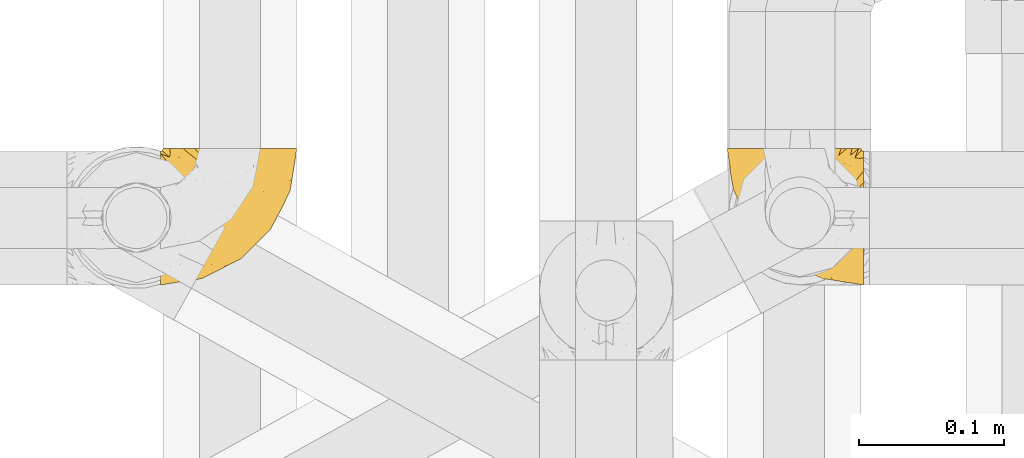
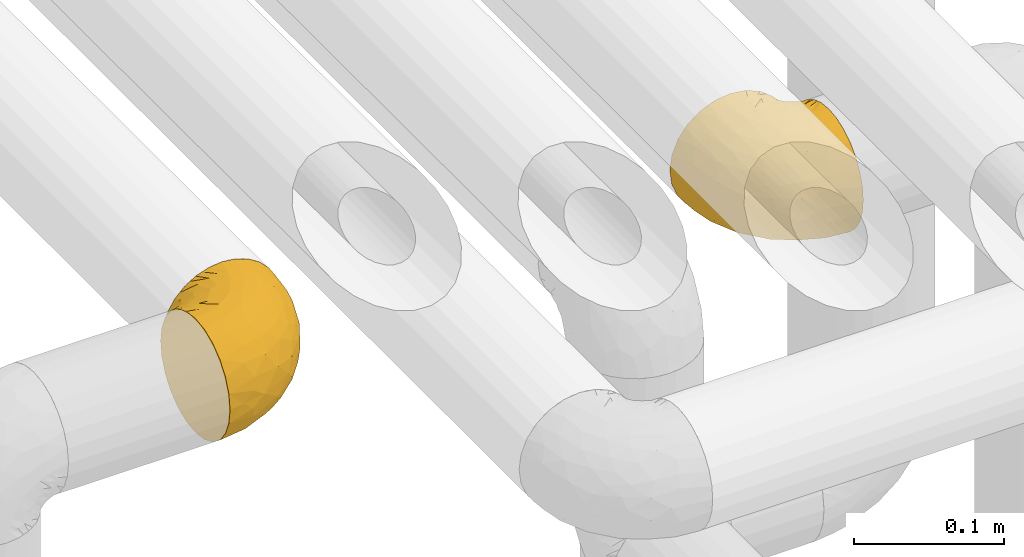
# One storey, part 175 of 827: 2 coverings.
"""IFC2X3 building model written with IfcOpenShell, lengths in millimetres."""

import ifcopenshell
import ifcopenshell.guid

model = None  # the IFC model being written
_history = None  # IfcOwnerHistory: only IFC2X3 demands one
_inside = {}  # id of a spatial element -> (the spatial element, [elements in it])
_under = {}  # id of a project, library or spatial element -> (it, [spatial elements below it])
_declared = {}  # id of a project -> (the project, [libraries it declares])
_typed = {}  # id of a type object -> (the type object, [elements of that type])
_made_of = {}  # id of a material, layer set ... -> (it, [elements and type objects made of it])


def new_model(schema):
    """Start an empty IFC model of exactly this schema.

    Asked for "IFC4X3", IfcOpenShell would pick the latest addendum, in which some entities
    have other attributes; the version numbers below select the first issue.
    IFC2X3 requires an IfcOwnerHistory on every rooted entity: one is made here for all.
    """
    global model, _history
    if schema == "IFC4X3":
        model = ifcopenshell.file(schema_version=(4, 3, 0, 0))
    else:
        model = ifcopenshell.file(schema=schema)
    _inside.clear()
    _under.clear()
    _declared.clear()
    _typed.clear()
    _made_of.clear()
    _history = None
    if model.schema == "IFC2X3":
        org = make("IfcOrganization", Name="unknown")
        user = make(
            "IfcPersonAndOrganization",
            ThePerson=make("IfcPerson", FamilyName="unknown"),
            TheOrganization=org,
        )
        app = make(
            "IfcApplication",
            ApplicationDeveloper=org,
            Version="unknown",
            ApplicationFullName="unknown",
            ApplicationIdentifier="unknown",
        )
        _history = make(
            "IfcOwnerHistory",
            OwningUser=user,
            OwningApplication=app,
            ChangeAction="ADDED",
            CreationDate=0,
        )
    return model


def make(cls, **values):
    """One entity of the class cls with the attributes given. An attribute that is None is left unset."""
    return model.create_entity(
        cls, **{name: value for name, value in values.items() if value is not None}
    )


def entity(cls, *values):
    """Any entity or typed value of the class cls, its attributes in the order of the schema. None: left unset."""
    e = model.create_entity(cls)
    for i, value in enumerate(values):
        if value is not None:
            e[i] = value
    return e


def rooted(cls, **values):
    """An entity with a GlobalId (a new one), such as an element, a storey or a relation."""
    return make(cls, GlobalId=ifcopenshell.guid.new(), OwnerHistory=_history, **values)


def si_unit(unit_type, name, prefix=None):
    """IfcSIUnit, for example si_unit("LENGTHUNIT", "METRE", prefix="MILLI")."""
    return make("IfcSIUnit", UnitType=unit_type, Prefix=prefix, Name=name)


def converted_unit(unit_type, name, factor, base, dimensions=None, offset=None):
    """IfcConversionBasedUnit, such as the inch: factor (a typed value) times the base unit."""
    return make(
        "IfcConversionBasedUnit"
        if offset is None
        else "IfcConversionBasedUnitWithOffset",
        ConversionOffset=offset,
        Dimensions=None
        if dimensions is None
        else entity("IfcDimensionalExponents", *dimensions),
        UnitType=unit_type,
        Name=name,
        ConversionFactor=make(
            "IfcMeasureWithUnit", ValueComponent=factor, UnitComponent=base
        ),
    )


def derived_unit(unit_type, elements):
    """IfcDerivedUnit: a product of units, each with its exponent."""
    return make(
        "IfcDerivedUnit",
        Elements=[
            make("IfcDerivedUnitElement", Unit=unit, Exponent=power)
            for unit, power in elements
        ],
        UnitType=unit_type,
    )


def assignment(units):
    """IfcUnitAssignment: the units of a project."""
    return None if units is None else make("IfcUnitAssignment", Units=units)


def point(xyz):
    """IfcCartesianPoint."""
    return None if xyz is None else make("IfcCartesianPoint", Coordinates=xyz)


def direction(xyz):
    """IfcDirection."""
    return None if xyz is None else make("IfcDirection", DirectionRatios=xyz)


def frame(location, z_axis=None, x_axis=None):
    """IfcAxis2Placement3D, a coordinate frame: its origin and axes. An axis left out is left unset."""
    return make(
        "IfcAxis2Placement3D",
        Location=point(location),
        Axis=direction(z_axis),
        RefDirection=direction(x_axis),
    )


def origin():
    """The frame at (0, 0, 0) with its axes left unset."""
    return frame((0.0, 0.0, 0.0))


def place(relative_to, where):
    """IfcLocalPlacement: puts the frame where relative to a parent placement (None: the world)."""
    return make(
        "IfcLocalPlacement", PlacementRelTo=relative_to, RelativePlacement=where
    )


def context(
    kind, dimensions, precision=None, world=None, true_north=None, identifier=None
):
    """IfcGeometricRepresentationContext, for example the 3D "Model" context."""
    return make(
        "IfcGeometricRepresentationContext",
        ContextIdentifier=identifier,
        ContextType=kind,
        CoordinateSpaceDimension=dimensions,
        Precision=precision,
        WorldCoordinateSystem=world,
        TrueNorth=true_north,
    )


def subcontext(parent, identifier, kind, view, scale=None):
    """IfcGeometricRepresentationSubContext, for example "Body" below "Model"."""
    return make(
        "IfcGeometricRepresentationSubContext",
        ContextIdentifier=identifier,
        ContextType=kind,
        ParentContext=parent,
        TargetScale=scale,
        TargetView=view,
    )


def project(units=None, contexts=None):
    """IfcProject with its units and contexts."""
    return rooted(
        "IfcProject",
        Name="project",
        RepresentationContexts=contexts,
        UnitsInContext=assignment(units),
    )


def spatial(cls, under=None, at=None, **own):
    """A site, building, storey or space (cls), placed at a placement, below another one or the project."""
    s = rooted(cls, ObjectPlacement=at, **own)
    if under is not None:
        _under.setdefault(under.id(), (under, []))[1].append(s)
    return s


def faces_of(points, faces, orient=None, outer=None):
    """IfcFace entities. A face is a list of loops; a loop is a list of indices into points, from 0.

    orient and outer hold one flag for each loop. By default every Orientation is true, the
    first loop of a face is its IfcFaceOuterBound and the others are IfcFaceBound.
    """
    made = []
    for i, loops in enumerate(faces):
        bounds = []
        for j, loop in enumerate(loops):
            is_outer = j == 0 if outer is None else outer[i][j]
            bounds.append(
                make(
                    "IfcFaceOuterBound" if is_outer else "IfcFaceBound",
                    Bound=make("IfcPolyLoop", Polygon=[points[k] for k in loop]),
                    Orientation=True if orient is None else orient[i][j],
                )
            )
        made.append(make("IfcFace", Bounds=bounds))
    return made


def faceted_brep(points, faces, orient=None, outer=None, voids=None):
    """IfcFacetedBrep: a solid bounded by flat faces; with voids (closed shells), ...WithVoids."""
    shared = [point(p) for p in points]
    hull = make("IfcClosedShell", CfsFaces=faces_of(shared, faces, orient, outer))
    if voids is None:
        return make("IfcFacetedBrep", Outer=hull)
    return make(
        "IfcFacetedBrepWithVoids",
        Outer=hull,
        Voids=[
            make(cls, CfsFaces=faces_of(shared, fs, o, b)) for cls, fs, o, b in voids
        ],
    )


def shape(context_of_items, identifier, shape_type, items):
    """IfcShapeRepresentation: the items that make up one representation, for example the "Body"."""
    return make(
        "IfcShapeRepresentation",
        ContextOfItems=context_of_items,
        RepresentationIdentifier=identifier,
        RepresentationType=shape_type,
        Items=items,
    )


def made_of(thing, what):
    """Note that an element or type object is made of a material, layer set ...; save() writes the relation."""
    if what is not None:
        _made_of.setdefault(what.id(), (what, []))[1].append(thing)
    return thing


def element(
    cls,
    number,
    at=None,
    inside=None,
    cuts=None,
    type_object=None,
    material=None,
    context=None,
    identifier="Body",
    shape_type=None,
    held_by="IfcProductDefinitionShape",
    body=None,
    shapes=None,
    **own,
):
    """One element of the class cls, such as IfcWall. Its Tag is "e" and its number.

    at: its placement. inside: the storey or other place that contains it. cuts: it is an
    opening in that element (IfcRelVoidsElement). A single representation is given by context,
    identifier, shape_type and body (its items); several are given by shapes. held_by: the class
    of the entity that holds the representations. save() writes the other relations.
    """
    e = rooted(cls, Tag="e%d" % number, ObjectPlacement=at, **own)
    if body is not None:
        shapes = [shape(context, identifier, shape_type, body)]
    if shapes is not None:
        e.Representation = make(held_by, Representations=shapes)
    if inside is not None:
        _inside.setdefault(inside.id(), (inside, []))[1].append(e)
    if cuts is not None:
        rooted(
            "IfcRelVoidsElement", RelatingBuildingElement=cuts, RelatedOpeningElement=e
        )
    if type_object is not None:
        _typed.setdefault(type_object.id(), (type_object, []))[1].append(e)
    return made_of(e, material)


def aggregate(whole, parts):
    """IfcRelAggregates: a whole, such as a stair, and the parts it consists of."""
    return rooted("IfcRelAggregates", RelatingObject=whole, RelatedObjects=parts)


def save(model, path):
    """Write the relations noted so far, then the file.

    IfcRelAggregates (storeys below a building ...), IfcRelContainedInSpatialStructure (elements
    in a storey), IfcRelDefinesByType, IfcRelAssociatesMaterial and IfcRelDeclares: one each for
    every whole, place, type object, material and project.
    """
    for whole, parts in _under.values():
        aggregate(whole, parts)
    for where, things in _inside.values():
        rooted(
            "IfcRelContainedInSpatialStructure",
            RelatedElements=things,
            RelatingStructure=where,
        )
    for kind, things in _typed.values():
        rooted("IfcRelDefinesByType", RelatedObjects=things, RelatingType=kind)
    for what, things in _made_of.values():
        rooted("IfcRelAssociatesMaterial", RelatedObjects=things, RelatingMaterial=what)
    for by, libraries in _declared.values():
        rooted("IfcRelDeclares", RelatingContext=by, RelatedDefinitions=libraries)
    model.write(path)


model = new_model("IFC2X3")

# Units and contexts
model_context = context("Model", 3, precision=0.01, world=origin(), true_north=direction((6.12303176911189e-17, 1.0)))
body_context = subcontext(model_context, "Body", "Model", "MODEL_VIEW")
ifc_project = project(units=[si_unit("LENGTHUNIT", "METRE", prefix="MILLI"), si_unit("AREAUNIT", "SQUARE_METRE"), si_unit("VOLUMEUNIT", "CUBIC_METRE"), converted_unit("PLANEANGLEUNIT", "DEGREE", entity("IfcRatioMeasure", 0.0174532925199433), si_unit("PLANEANGLEUNIT", "RADIAN"), dimensions=[0, 0, 0, 0, 0, 0, 0]), si_unit("MASSUNIT", "GRAM", prefix="KILO"), derived_unit("MASSDENSITYUNIT", [(si_unit("MASSUNIT", "GRAM", prefix="KILO"), 1), (si_unit("LENGTHUNIT", "METRE"), -3)]), derived_unit("MOMENTOFINERTIAUNIT", [(si_unit("LENGTHUNIT", "METRE"), 4)]), si_unit("TIMEUNIT", "SECOND"), si_unit("FREQUENCYUNIT", "HERTZ"), si_unit("THERMODYNAMICTEMPERATUREUNIT", "DEGREE_CELSIUS"), derived_unit("THERMALTRANSMITTANCEUNIT", [(si_unit("MASSUNIT", "GRAM", prefix="KILO"), 1), (si_unit("THERMODYNAMICTEMPERATUREUNIT", "KELVIN"), -1), (si_unit("TIMEUNIT", "SECOND"), -3)]), derived_unit("VOLUMETRICFLOWRATEUNIT", [(si_unit("LENGTHUNIT", "METRE"), 3), (si_unit("TIMEUNIT", "SECOND"), -1)]), derived_unit("MASSFLOWRATEUNIT", [(si_unit("MASSUNIT", "GRAM", prefix="KILO"), 1), (si_unit("TIMEUNIT", "SECOND"), -1)]), derived_unit("ROTATIONALFREQUENCYUNIT", [(si_unit("TIMEUNIT", "SECOND"), -1)]), si_unit("ELECTRICCURRENTUNIT", "AMPERE"), si_unit("ELECTRICVOLTAGEUNIT", "VOLT"), si_unit("POWERUNIT", "WATT"), si_unit("FORCEUNIT", "NEWTON", prefix="KILO"), si_unit("ILLUMINANCEUNIT", "LUX"), si_unit("LUMINOUSFLUXUNIT", "LUMEN"), si_unit("LUMINOUSINTENSITYUNIT", "CANDELA"), derived_unit("USERDEFINED", [(si_unit("MASSUNIT", "GRAM", prefix="KILO"), -1), (si_unit("LENGTHUNIT", "METRE"), -2), (si_unit("TIMEUNIT", "SECOND"), 3), (si_unit("LUMINOUSFLUXUNIT", "LUMEN"), 1)]), derived_unit("LINEARVELOCITYUNIT", [(si_unit("LENGTHUNIT", "METRE"), 1), (si_unit("TIMEUNIT", "SECOND"), -1)]), si_unit("PRESSUREUNIT", "PASCAL"), derived_unit("USERDEFINED", [(si_unit("LENGTHUNIT", "METRE"), -2), (si_unit("MASSUNIT", "GRAM", prefix="KILO"), 1), (si_unit("TIMEUNIT", "SECOND"), -2)]), derived_unit("LINEARFORCEUNIT", [(si_unit("MASSUNIT", "GRAM", prefix="KILO"), 1), (si_unit("LENGTHUNIT", "METRE"), 1), (si_unit("TIMEUNIT", "SECOND"), -2), (si_unit("LENGTHUNIT", "METRE"), -1)]), derived_unit("PLANARFORCEUNIT", [(si_unit("MASSUNIT", "GRAM", prefix="KILO"), 1), (si_unit("LENGTHUNIT", "METRE"), 1), (si_unit("TIMEUNIT", "SECOND"), -2), (si_unit("LENGTHUNIT", "METRE"), -2)])], contexts=[model_context])

# Site, building, storey
site_placement = place(None, origin())
site = spatial("IfcSite", under=ifc_project, at=site_placement, CompositionType="ELEMENT")
building_placement = place(site_placement, origin())
building = spatial("IfcBuilding", under=site, at=building_placement, CompositionType="ELEMENT")
storey_placement = place(building_placement, frame((0.0, 0.0, 28200.0)))
storey = spatial("IfcBuildingStorey", under=building, at=storey_placement, Name="08", CompositionType="ELEMENT", Elevation=28200.0)

# Coverings
covering_1_placement = place(storey_placement, frame((35682.24, 12958.41, 2952.2)))
element("IfcCovering", 1, at=covering_1_placement, inside=storey, Name=":ADSK_", ObjectType=":ADSK_", PredefinedType="INSULATION", context=body_context, shape_type="Brep", body=[
    faceted_brep([(95.8, 18.98, 83.91), (95.8, 11.67, 76.59), (95.8, 6.17, 67.83), (95.8, 2.75, 58.07), (95.8, 1.6, 47.8), (95.8, 2.75, 37.51), (95.8, 6.17, 27.74), (95.8, 11.68, 18.98), (95.8, 19.0, 11.67), (95.8, 27.76, 6.17), (95.8, 37.52, 2.75), (95.8, 47.8, 1.6), (95.8, 51.94, 2.06), (95.8, 55.01, 2.41), (95.8, 58.08, 2.75), (95.8, 62.96, 4.46), (95.8, 67.85, 6.17), (95.8, 72.23, 8.93), (95.8, 76.61, 11.68), (95.8, 80.26, 15.34), (95.8, 83.92, 19.0), (95.8, 89.42, 27.76), (95.8, 91.13, 32.64), (95.8, 92.84, 37.52), (95.8, 94.0, 47.8), (95.8, 92.84, 58.08), (95.8, 91.13, 62.96), (95.8, 89.42, 67.85), (95.8, 83.91, 76.61), (95.8, 80.25, 80.26), (95.8, 76.59, 83.92), (95.8, 72.21, 86.67), (95.8, 67.83, 89.42), (95.8, 62.95, 91.13), (95.8, 58.07, 92.84), (95.8, 55.0, 93.18), (95.8, 51.94, 93.53), (95.8, 47.8, 94.0), (95.8, 37.51, 92.84), (95.8, 27.74, 89.42), (94.0, 95.8, 47.8), (92.42, 95.8, 35.84), (87.81, 95.8, 24.7), (84.13, 95.8, 19.91), (80.46, 95.8, 15.13), (75.68, 95.8, 11.46), (70.9, 95.8, 7.78), (65.32, 95.8, 5.48), (59.75, 95.8, 3.17), (56.14, 95.8, 2.69), (54.06, 95.8, 2.42), (51.97, 95.8, 2.14), (47.8, 95.8, 1.6), (35.84, 95.8, 3.17), (24.7, 95.8, 7.78), (15.13, 95.8, 15.13), (7.78, 95.8, 24.7), (3.17, 95.8, 35.84), (1.6, 95.8, 47.8), (3.17, 95.8, 59.75), (7.78, 95.8, 70.9), (15.13, 95.8, 80.46), (24.7, 95.8, 87.81), (35.84, 95.8, 92.42), (47.8, 95.8, 94.0), (51.97, 95.8, 93.45), (56.14, 95.8, 92.9), (59.75, 95.8, 92.42), (65.32, 95.8, 90.11), (70.9, 95.8, 87.81), (75.68, 95.8, 84.13), (80.46, 95.8, 80.46), (84.13, 95.8, 75.68), (87.81, 95.8, 70.9), (92.42, 95.8, 59.75), (15.84, 60.58, 71.98), (6.99, 74.11, 63.6), (14.39, 51.59, 59.72), (6.21, 66.69, 47.8), (4.26, 76.19, 55.16), (3.39, 84.43, 47.8), (31.2, 31.2, 63.76), (26.47, 42.88, 72.22), (11.44, 79.41, 74.18), (47.66, 60.7, 92.52), (61.85, 61.85, 94.0), (59.25, 65.75, 94.0), (56.65, 69.64, 94.0), (54.05, 73.53, 94.0), (51.45, 77.43, 94.0), (19.8, 74.59, 82.14), (26.22, 54.72, 80.34), (31.58, 64.18, 87.52), (38.36, 37.94, 79.59), (51.54, 25.89, 78.25), (51.6, 34.73, 85.01), (55.97, 42.89, 90.25), (62.88, 49.83, 93.2), (41.35, 48.58, 87.23), (82.24, 22.41, 85.55), (40.88, 78.69, 93.0), (29.0, 81.64, 89.31), (74.06, 6.22, 61.31), (54.53, 12.11, 56.86), (57.98, 14.81, 68.34), (43.81, 21.61, 65.71), (38.22, 22.41, 56.99), (38.33, 30.12, 72.15), (74.76, 10.01, 70.34), (76.85, 15.36, 78.36), (84.43, 3.39, 47.8), (40.43, 19.59, 47.8), (30.01, 30.01, 47.8), (78.67, 41.19, 93.06), (92.06, 48.54, 94.0), (88.32, 49.28, 94.0), (85.6, 49.82, 94.0), (82.88, 50.37, 94.0), (80.15, 50.91, 94.0), (77.43, 51.45, 94.0), (76.36, 31.61, 89.88), (50.91, 80.15, 94.0), (50.37, 82.88, 94.0), (49.82, 85.6, 94.0), (49.28, 88.32, 94.0), (48.91, 90.19, 94.0), (48.54, 92.06, 94.0), (66.69, 6.21, 47.8), (73.53, 54.05, 94.0), (69.64, 56.65, 94.0), (65.75, 59.25, 94.0), (66.13, 24.66, 83.7), (19.59, 40.43, 47.8), (24.64, 35.17, 55.9), (53.56, 12.9, 47.8), (12.9, 53.56, 47.8), (82.81, 85.34, 81.75), (81.22, 78.44, 86.43), (86.57, 84.37, 79.8), (92.75, 89.05, 69.84), (89.68, 82.76, 79.5), (72.26, 86.31, 88.08), (64.73, 83.73, 91.6), (62.45, 77.31, 92.93), (60.63, 87.78, 92.43), (56.91, 87.91, 93.24), (58.14, 81.29, 93.36), (93.7, 93.97, 57.25), (83.4, 70.76, 89.41), (75.54, 63.67, 92.89), (79.46, 62.62, 92.66), (82.28, 90.64, 79.58), (76.25, 84.08, 86.51), (90.18, 77.45, 83.91), (84.69, 76.28, 86.29), (86.94, 91.35, 73.94), (65.12, 88.72, 90.94), (71.71, 71.28, 91.94), (75.21, 68.09, 91.98), (78.6, 91.07, 82.79), (87.27, 57.47, 93.16), (87.92, 70.34, 88.76), (86.1, 62.99, 91.89), (94.52, 94.52, 47.8), (66.23, 76.47, 92.22), (91.08, 69.96, 88.56), (71.77, 89.86, 87.72), (76.21, 78.94, 88.33), (68.59, 73.51, 92.18), (89.94, 89.62, 71.78), (76.22, 78.96, 7.27), (81.22, 78.46, 9.17), (71.7, 71.31, 3.66), (49.28, 88.32, 1.6), (48.54, 92.06, 1.6), (50.37, 82.88, 1.6), (49.82, 85.6, 1.6), (93.7, 93.97, 38.35), (89.95, 89.63, 23.84), (82.88, 50.37, 1.6), (85.6, 49.82, 1.6), (92.06, 48.54, 1.6), (88.32, 49.28, 1.6), (89.68, 82.77, 16.1), (87.92, 70.36, 6.84), (62.45, 77.31, 2.66), (66.24, 76.47, 3.37), (56.65, 69.64, 1.6), (59.25, 65.75, 1.6), (78.6, 91.06, 12.8), (60.63, 87.78, 3.16), (56.91, 87.91, 2.35), (92.76, 89.06, 25.77), (76.25, 84.09, 9.09), (82.28, 90.65, 16.02), (82.81, 85.35, 13.85), (54.05, 73.53, 1.6), (51.45, 77.43, 1.6), (58.14, 81.29, 2.23), (90.18, 77.46, 11.69), (84.7, 76.29, 9.31), (87.25, 57.47, 2.43), (75.58, 63.71, 2.71), (75.2, 68.11, 3.61), (83.39, 70.77, 6.18), (90.73, 69.52, 6.77), (79.47, 62.64, 2.93), (86.94, 91.35, 21.66), (65.75, 59.25, 1.6), (86.75, 84.6, 16.09), (86.08, 62.98, 3.7), (77.43, 51.45, 1.6), (73.53, 54.05, 1.6), (69.64, 56.65, 1.6), (64.73, 83.73, 3.99), (50.91, 80.15, 1.6), (65.12, 88.72, 4.65), (72.26, 86.3, 7.51), (61.85, 61.85, 1.6), (68.62, 73.56, 3.43), (74.03, 91.36, 9.46), (80.15, 50.91, 1.6), (49.81, 62.87, 2.4), (4.26, 76.19, 40.43), (19.95, 73.57, 13.57), (30.61, 56.07, 11.3), (25.71, 49.77, 18.65), (22.43, 44.73, 27.26), (15.85, 60.58, 23.61), (60.69, 47.64, 3.07), (40.49, 78.32, 2.69), (14.39, 51.59, 35.87), (6.99, 74.11, 31.99), (29.56, 76.04, 6.71), (11.45, 79.41, 21.41), (57.98, 14.82, 27.24), (74.06, 6.22, 34.26), (54.52, 12.12, 38.73), (43.47, 23.51, 26.97), (31.2, 31.2, 31.83), (33.27, 34.96, 23.4), (64.26, 33.86, 6.91), (74.29, 38.94, 3.4), (80.41, 30.23, 5.84), (41.67, 20.67, 35.73), (24.64, 35.17, 39.69), (73.62, 15.85, 17.6), (78.98, 22.59, 10.38), (53.69, 21.56, 20.6), (42.86, 55.94, 5.36), (79.66, 9.19, 24.84), (58.41, 25.79, 13.87), (47.11, 41.16, 9.06), (38.37, 37.95, 15.99)], [[[0, 1, 2, 3, 4, 5, 6, 7, 8, 9, 10, 11, 12, 13, 14, 15, 16, 17, 18, 19, 20, 21, 22, 23, 24, 25, 26, 27, 28, 29, 30, 31, 32, 33, 34, 35, 36, 37, 38, 39]], [[40, 41, 42, 43, 44, 45, 46, 47, 48, 49, 50, 51, 52, 53, 54, 55, 56, 57, 58, 59, 60, 61, 62, 63, 64, 65, 66, 67, 68, 69, 70, 71, 72, 73, 74]], [[75, 76, 77]], [[78, 79, 80]], [[77, 81, 82]], [[76, 75, 83]], [[84, 85, 86, 87, 88, 89]], [[90, 91, 92]], [[76, 60, 59]], [[93, 94, 95]], [[90, 62, 61]], [[83, 61, 60]], [[96, 97, 84]], [[98, 93, 95]], [[0, 39, 99]], [[100, 84, 89]], [[62, 101, 63]], [[2, 102, 3]], [[92, 84, 100]], [[103, 102, 104]], [[103, 105, 106]], [[93, 107, 94]], [[1, 108, 2]], [[92, 101, 90]], [[108, 1, 109]], [[102, 110, 3]], [[93, 82, 107]], [[102, 108, 104]], [[111, 106, 112]], [[109, 0, 99]], [[113, 37, 114, 115, 116, 117, 118, 119]], [[120, 38, 113]], [[100, 89, 121, 122, 123, 124, 125, 126, 64]], [[127, 102, 103]], [[97, 119, 128, 129, 130, 85]], [[99, 120, 131]], [[132, 133, 77]], [[59, 80, 79]], [[1, 0, 109]], [[98, 84, 92]], [[94, 109, 131]], [[120, 39, 38]], [[93, 91, 82]], [[104, 94, 105]], [[97, 113, 119]], [[95, 120, 96]], [[83, 90, 61]], [[91, 93, 98]], [[64, 63, 100]], [[100, 63, 101]], [[77, 76, 79]], [[133, 106, 81]], [[84, 97, 85]], [[113, 96, 120]], [[113, 97, 96]], [[37, 113, 38]], [[110, 102, 127]], [[110, 4, 3]], [[103, 111, 134, 127]], [[90, 75, 91]], [[82, 81, 107]], [[91, 75, 82]], [[77, 82, 75]], [[76, 83, 60]], [[90, 83, 75]], [[105, 107, 81]], [[94, 131, 95]], [[105, 94, 107]], [[109, 94, 104]], [[120, 95, 131]], [[98, 95, 96]], [[84, 98, 96]], [[98, 92, 91]], [[106, 105, 81]], [[103, 104, 105]], [[112, 106, 133]], [[103, 106, 111]], [[112, 133, 132]], [[81, 77, 133]], [[77, 78, 135, 132]], [[120, 99, 39]], [[109, 99, 131]], [[59, 58, 80]], [[59, 79, 76]], [[90, 101, 62]], [[100, 101, 92]], [[2, 108, 102]], [[109, 104, 108]], [[78, 77, 79]], [[136, 137, 138]], [[27, 139, 140]], [[141, 142, 143]], [[144, 145, 121]], [[146, 89, 88]], [[147, 139, 25]], [[148, 149, 150]], [[136, 151, 152]], [[147, 40, 74]], [[24, 147, 25]], [[153, 140, 154]], [[33, 116, 34]], [[73, 151, 155]], [[114, 37, 36, 35, 34, 116, 115]], [[146, 156, 144]], [[157, 85, 130]], [[158, 149, 148]], [[151, 159, 152]], [[117, 33, 160]], [[29, 153, 161]], [[155, 74, 73]], [[162, 128, 119]], [[66, 65, 64, 126, 125, 124, 123, 122, 67]], [[163, 147, 24]], [[27, 140, 28]], [[149, 129, 150]], [[139, 27, 26, 25]], [[68, 144, 69]], [[129, 128, 150]], [[164, 87, 86]], [[130, 129, 149]], [[122, 145, 67]], [[153, 154, 148]], [[162, 119, 160]], [[165, 30, 161]], [[150, 161, 148]], [[128, 162, 150]], [[30, 165, 31]], [[145, 144, 68]], [[89, 146, 144]], [[87, 164, 143]], [[166, 156, 142]], [[88, 87, 143]], [[162, 161, 150]], [[161, 30, 29]], [[161, 153, 148]], [[28, 140, 153]], [[29, 28, 153]], [[140, 137, 154]], [[158, 148, 154]], [[157, 130, 158]], [[154, 137, 158]], [[158, 137, 157]], [[167, 137, 136]], [[168, 85, 157]], [[152, 168, 167]], [[167, 168, 157]], [[164, 152, 141]], [[151, 73, 72]], [[159, 72, 71]], [[88, 142, 146]], [[144, 156, 69]], [[146, 142, 156]], [[70, 166, 71]], [[142, 141, 166]], [[70, 69, 156]], [[141, 159, 71]], [[167, 136, 152]], [[138, 137, 140]], [[155, 136, 169]], [[136, 155, 151]], [[74, 155, 169]], [[152, 159, 141]], [[151, 72, 159]], [[168, 152, 164]], [[137, 167, 157]], [[164, 86, 168]], [[85, 168, 86]], [[116, 33, 117]], [[130, 149, 158]], [[67, 145, 68]], [[121, 89, 144]], [[145, 122, 121]], [[40, 147, 163]], [[169, 147, 74]], [[160, 33, 32]], [[162, 160, 32]], [[160, 119, 118, 117]], [[139, 147, 169]], [[139, 169, 138]], [[162, 32, 31]], [[141, 143, 164]], [[88, 143, 142]], [[71, 166, 141]], [[156, 166, 70]], [[139, 138, 140]], [[169, 136, 138]], [[161, 162, 165]], [[162, 31, 165]], [[170, 171, 172]], [[173, 174, 52, 51, 50, 49, 48, 175, 176]], [[177, 178, 41]], [[179, 15, 180]], [[12, 11, 181, 182, 180, 14, 13]], [[183, 21, 20]], [[19, 18, 184]], [[185, 186, 187]], [[186, 188, 187]], [[43, 189, 44]], [[190, 191, 47]], [[23, 22, 21, 192]], [[193, 194, 195]], [[40, 163, 177]], [[196, 197, 198]], [[24, 23, 177]], [[199, 200, 183]], [[201, 15, 179]], [[178, 177, 192]], [[47, 46, 190]], [[202, 203, 204]], [[203, 172, 171]], [[205, 206, 184]], [[207, 41, 178]], [[16, 15, 201]], [[14, 180, 15]], [[204, 203, 200]], [[208, 203, 202]], [[163, 24, 177]], [[48, 47, 191]], [[198, 197, 190]], [[199, 184, 204]], [[171, 195, 209]], [[210, 211, 212]], [[206, 212, 213]], [[205, 17, 210]], [[184, 206, 204]], [[210, 212, 206]], [[185, 196, 214]], [[190, 215, 191]], [[216, 45, 214]], [[186, 217, 193]], [[190, 216, 198]], [[199, 20, 19]], [[196, 185, 187]], [[199, 183, 20]], [[184, 199, 19]], [[199, 204, 200]], [[206, 202, 204]], [[171, 183, 200]], [[203, 208, 172]], [[172, 208, 218]], [[171, 200, 203]], [[218, 188, 219]], [[195, 170, 193]], [[217, 186, 185]], [[193, 219, 186]], [[193, 170, 219]], [[207, 194, 42]], [[217, 220, 189]], [[216, 190, 46]], [[214, 196, 198]], [[44, 220, 45]], [[214, 198, 216]], [[216, 46, 45]], [[214, 45, 220]], [[42, 194, 43]], [[189, 193, 217]], [[207, 195, 194]], [[209, 195, 178]], [[41, 207, 42]], [[195, 207, 178]], [[43, 194, 189]], [[193, 189, 194]], [[171, 170, 195]], [[170, 172, 219]], [[218, 219, 172]], [[188, 186, 219]], [[206, 213, 202]], [[208, 202, 213]], [[201, 210, 16]], [[215, 190, 197]], [[215, 175, 191]], [[175, 48, 191]], [[201, 179, 221, 211]], [[210, 201, 211]], [[23, 192, 177]], [[40, 177, 41]], [[192, 183, 209]], [[21, 183, 192]], [[205, 18, 17]], [[17, 16, 210]], [[217, 185, 214]], [[189, 220, 44]], [[214, 220, 217]], [[192, 209, 178]], [[171, 209, 183]], [[206, 205, 210]], [[18, 205, 184]], [[222, 197, 196, 187, 188, 218]], [[57, 223, 80]], [[224, 225, 226]], [[226, 227, 228]], [[229, 218, 208, 213, 212, 211]], [[230, 52, 174, 173, 176, 175, 215, 197]], [[231, 232, 228]], [[231, 78, 223]], [[223, 57, 232]], [[224, 233, 225]], [[233, 54, 53]], [[234, 232, 56]], [[56, 55, 234]], [[234, 224, 228]], [[235, 236, 237]], [[224, 55, 54]], [[238, 239, 240]], [[52, 230, 53]], [[241, 242, 243]], [[239, 244, 245]], [[11, 10, 242]], [[236, 6, 5]], [[7, 246, 8]], [[8, 247, 9]], [[238, 248, 235]], [[222, 229, 249]], [[242, 211, 221, 179, 180, 182, 181, 11]], [[233, 53, 230]], [[111, 112, 244]], [[250, 6, 236]], [[247, 251, 241]], [[6, 250, 7]], [[127, 236, 110]], [[249, 229, 252]], [[247, 8, 246]], [[235, 246, 250]], [[236, 5, 110]], [[235, 244, 238]], [[237, 236, 127]], [[243, 9, 247]], [[252, 229, 241]], [[56, 232, 57]], [[222, 230, 197]], [[225, 249, 252]], [[249, 233, 230]], [[54, 233, 224]], [[231, 228, 227]], [[245, 132, 231]], [[249, 225, 233]], [[226, 225, 253]], [[235, 250, 236]], [[246, 7, 250]], [[251, 247, 246]], [[243, 247, 241]], [[248, 246, 235]], [[252, 251, 253]], [[229, 222, 218]], [[230, 222, 249]], [[5, 4, 110]], [[237, 127, 134, 111]], [[238, 244, 239]], [[224, 234, 55]], [[232, 234, 228]], [[242, 241, 229]], [[10, 9, 243]], [[211, 242, 229]], [[10, 243, 242]], [[80, 223, 78]], [[80, 58, 57]], [[231, 223, 232]], [[227, 240, 239]], [[224, 226, 228]], [[240, 226, 253]], [[227, 239, 245]], [[226, 240, 227]], [[251, 248, 253]], [[240, 253, 248]], [[244, 235, 237]], [[237, 111, 244]], [[132, 245, 112]], [[112, 245, 244]], [[135, 78, 231, 132]], [[227, 245, 231]], [[248, 238, 240]], [[246, 248, 251]], [[251, 252, 241]], [[225, 252, 253]]]),
])
covering_2_placement = place(storey_placement, frame((35290.44, 12958.41, 2952.2)))
element("IfcCovering", 2, at=covering_2_placement, inside=storey, Name=":ADSK_", ObjectType=":ADSK_", PredefinedType="INSULATION", context=body_context, shape_type="Brep", body=[
    faceted_brep([(78.41, 95.8, 83.91), (85.72, 95.8, 76.59), (91.22, 95.8, 67.83), (94.64, 95.8, 58.07), (95.8, 95.8, 47.8), (94.64, 95.8, 37.51), (91.22, 95.8, 27.74), (85.71, 95.8, 18.98), (78.39, 95.8, 11.67), (69.63, 95.8, 6.17), (59.87, 95.8, 2.75), (49.6, 95.8, 1.6), (45.45, 95.8, 2.06), (42.38, 95.8, 2.41), (39.31, 95.8, 2.75), (34.43, 95.8, 4.46), (29.54, 95.8, 6.17), (25.16, 95.8, 8.93), (20.78, 95.8, 11.68), (17.13, 95.8, 15.34), (13.47, 95.8, 19.0), (7.97, 95.8, 27.76), (6.26, 95.8, 32.64), (4.55, 95.8, 37.52), (3.4, 95.8, 47.8), (4.55, 95.8, 58.08), (6.26, 95.8, 62.96), (7.97, 95.8, 67.85), (13.48, 95.8, 76.61), (17.14, 95.8, 80.26), (20.8, 95.8, 83.92), (25.18, 95.8, 86.67), (29.56, 95.8, 89.42), (34.44, 95.8, 91.13), (39.32, 95.8, 92.84), (42.39, 95.8, 93.18), (45.45, 95.8, 93.53), (49.6, 95.8, 94.0), (59.88, 95.8, 92.84), (69.65, 95.8, 89.42), (1.6, 94.0, 47.8), (1.6, 92.42, 35.84), (1.6, 87.81, 24.7), (1.6, 84.13, 19.91), (1.6, 80.46, 15.13), (1.6, 75.68, 11.46), (1.6, 70.9, 7.78), (1.6, 65.32, 5.48), (1.6, 59.75, 3.17), (1.6, 56.14, 2.69), (1.6, 54.06, 2.42), (1.6, 51.97, 2.14), (1.6, 47.8, 1.6), (1.6, 35.84, 3.17), (1.6, 24.7, 7.78), (1.6, 15.13, 15.13), (1.6, 7.78, 24.7), (1.6, 3.17, 35.84), (1.6, 1.6, 47.8), (1.6, 3.17, 59.75), (1.6, 7.78, 70.9), (1.6, 15.13, 80.46), (1.6, 24.7, 87.81), (1.6, 35.84, 92.42), (1.6, 47.8, 94.0), (1.6, 51.97, 93.45), (1.6, 56.14, 92.9), (1.6, 59.75, 92.42), (1.6, 65.32, 90.11), (1.6, 70.9, 87.81), (1.6, 75.68, 84.13), (1.6, 80.46, 80.46), (1.6, 84.13, 75.68), (1.6, 87.81, 70.9), (1.6, 92.42, 59.75), (36.81, 15.84, 71.98), (23.28, 6.99, 63.6), (45.8, 14.39, 59.72), (30.7, 6.21, 47.8), (21.2, 4.26, 55.16), (12.96, 3.39, 47.8), (66.19, 31.2, 63.76), (54.51, 26.47, 72.22), (17.98, 11.44, 74.18), (36.69, 47.66, 92.52), (35.54, 61.85, 94.0), (31.64, 59.25, 94.0), (27.75, 56.65, 94.0), (23.86, 54.05, 94.0), (19.96, 51.45, 94.0), (22.8, 19.8, 82.14), (42.67, 26.22, 80.34), (33.21, 31.58, 87.52), (59.45, 38.36, 79.59), (71.5, 51.54, 78.25), (62.66, 51.6, 85.01), (54.5, 55.97, 90.25), (47.57, 62.88, 93.2), (48.81, 41.35, 87.23), (74.98, 82.24, 85.55), (18.7, 40.88, 93.0), (15.75, 29.0, 89.31), (91.17, 74.06, 61.31), (85.28, 54.53, 56.86), (82.58, 57.98, 68.34), (75.78, 43.81, 65.71), (74.98, 38.22, 56.99), (67.27, 38.33, 72.15), (87.38, 74.76, 70.34), (82.04, 76.85, 78.36), (94.0, 84.43, 47.8), (77.8, 40.43, 47.8), (67.38, 30.01, 47.8), (56.2, 78.67, 93.06), (48.85, 92.06, 94.0), (48.11, 88.32, 94.0), (47.57, 85.6, 94.0), (47.03, 82.88, 94.0), (46.48, 80.15, 94.0), (45.94, 77.43, 94.0), (65.78, 76.36, 89.88), (17.24, 50.91, 94.0), (14.51, 50.37, 94.0), (11.79, 49.82, 94.0), (9.07, 49.28, 94.0), (7.2, 48.91, 94.0), (5.33, 48.54, 94.0), (91.18, 66.69, 47.8), (43.34, 73.53, 94.0), (40.74, 69.64, 94.0), (38.14, 65.75, 94.0), (72.73, 66.13, 83.7), (56.96, 19.59, 47.8), (62.23, 24.64, 55.9), (84.49, 53.56, 47.8), (43.83, 12.9, 47.8), (12.05, 82.81, 81.75), (18.95, 81.22, 86.43), (13.02, 86.57, 79.8), (8.34, 92.75, 69.84), (14.63, 89.68, 79.5), (11.09, 72.26, 88.08), (13.66, 64.73, 91.6), (20.08, 62.45, 92.93), (9.61, 60.63, 92.43), (9.48, 56.91, 93.24), (16.1, 58.14, 93.36), (3.42, 93.7, 57.25), (26.63, 83.4, 89.41), (33.72, 75.54, 92.89), (34.77, 79.46, 92.66), (6.75, 82.28, 79.58), (13.31, 76.25, 86.51), (21.11, 84.69, 86.29), (19.94, 90.18, 83.91), (6.04, 86.94, 73.94), (8.67, 65.12, 90.94), (26.11, 71.71, 91.94), (29.3, 75.21, 91.98), (6.32, 78.6, 82.79), (39.92, 87.27, 93.16), (27.05, 87.92, 88.76), (34.4, 86.1, 91.89), (2.87, 94.52, 47.8), (20.92, 66.23, 92.22), (27.43, 91.08, 88.56), (7.54, 71.77, 87.72), (18.45, 76.21, 88.33), (23.88, 68.59, 92.18), (7.77, 89.94, 71.78), (13.3, 76.25, 9.09), (11.09, 72.26, 7.51), (6.33, 78.6, 12.8), (9.07, 49.28, 1.6), (5.33, 48.54, 1.6), (14.51, 50.37, 1.6), (11.79, 49.82, 1.6), (3.42, 93.7, 38.35), (7.76, 89.95, 23.84), (47.03, 82.88, 1.6), (47.57, 85.6, 1.6), (48.85, 92.06, 1.6), (48.11, 88.32, 1.6), (14.62, 89.68, 16.1), (27.03, 87.92, 6.84), (20.08, 62.45, 2.66), (20.92, 66.24, 3.37), (27.75, 56.65, 1.6), (31.64, 59.25, 1.6), (9.61, 60.63, 3.16), (9.48, 56.91, 2.35), (8.33, 92.76, 25.77), (6.74, 82.28, 16.02), (12.04, 82.81, 13.85), (23.86, 54.05, 1.6), (19.96, 51.45, 1.6), (16.1, 58.14, 2.23), (19.93, 90.18, 11.69), (21.1, 84.7, 9.31), (39.92, 87.25, 2.43), (33.68, 75.58, 2.71), (29.28, 75.2, 3.61), (26.62, 83.39, 6.18), (26.08, 71.7, 3.66), (18.93, 81.22, 9.17), (27.87, 90.73, 6.77), (34.75, 79.47, 2.93), (6.04, 86.94, 21.66), (38.14, 65.75, 1.6), (12.79, 86.75, 16.09), (34.41, 86.08, 3.7), (45.94, 77.43, 1.6), (43.34, 73.53, 1.6), (40.74, 69.64, 1.6), (13.66, 64.73, 3.99), (17.24, 50.91, 1.6), (8.67, 65.12, 4.65), (35.54, 61.85, 1.6), (23.83, 68.62, 3.43), (18.43, 76.22, 7.27), (6.03, 74.03, 9.46), (46.48, 80.15, 1.6), (34.52, 49.81, 2.4), (21.2, 4.26, 40.43), (23.82, 19.95, 13.57), (41.32, 30.61, 11.3), (47.62, 25.71, 18.65), (52.66, 22.43, 27.26), (36.81, 15.85, 23.61), (49.75, 60.69, 3.07), (19.07, 40.49, 2.69), (45.8, 14.39, 35.87), (23.28, 6.99, 31.99), (21.35, 29.56, 6.71), (17.98, 11.45, 21.41), (82.57, 57.98, 27.24), (91.17, 74.06, 34.26), (85.27, 54.52, 38.73), (73.89, 43.47, 26.97), (66.19, 31.2, 31.83), (62.43, 33.27, 23.4), (63.53, 64.26, 6.91), (58.45, 74.29, 3.4), (67.16, 80.41, 5.84), (62.22, 24.64, 39.69), (81.54, 73.62, 17.6), (74.8, 78.98, 10.38), (75.83, 53.69, 20.6), (41.45, 42.86, 5.36), (76.72, 41.67, 35.73), (88.2, 79.66, 24.84), (71.6, 58.41, 13.87), (56.23, 47.11, 9.06), (59.44, 38.37, 15.99)], [[[0, 1, 2, 3, 4, 5, 6, 7, 8, 9, 10, 11, 12, 13, 14, 15, 16, 17, 18, 19, 20, 21, 22, 23, 24, 25, 26, 27, 28, 29, 30, 31, 32, 33, 34, 35, 36, 37, 38, 39]], [[40, 41, 42, 43, 44, 45, 46, 47, 48, 49, 50, 51, 52, 53, 54, 55, 56, 57, 58, 59, 60, 61, 62, 63, 64, 65, 66, 67, 68, 69, 70, 71, 72, 73, 74]], [[75, 76, 77]], [[78, 79, 80]], [[77, 81, 82]], [[76, 75, 83]], [[84, 85, 86, 87, 88, 89]], [[90, 91, 92]], [[76, 60, 59]], [[93, 94, 95]], [[90, 62, 61]], [[83, 61, 60]], [[96, 97, 84]], [[98, 93, 95]], [[0, 39, 99]], [[100, 84, 89]], [[62, 101, 63]], [[2, 102, 3]], [[92, 84, 100]], [[103, 102, 104]], [[103, 105, 106]], [[93, 107, 94]], [[1, 108, 2]], [[92, 101, 90]], [[108, 1, 109]], [[102, 110, 3]], [[93, 82, 107]], [[102, 108, 104]], [[111, 106, 112]], [[109, 0, 99]], [[113, 37, 114, 115, 116, 117, 118, 119]], [[120, 38, 113]], [[100, 89, 121, 122, 123, 124, 125, 126, 64]], [[127, 102, 103]], [[97, 119, 128, 129, 130, 85]], [[99, 120, 131]], [[132, 133, 77]], [[59, 80, 79]], [[1, 0, 109]], [[98, 84, 92]], [[94, 109, 131]], [[120, 39, 38]], [[93, 91, 82]], [[104, 94, 105]], [[97, 113, 119]], [[95, 120, 96]], [[83, 90, 61]], [[91, 93, 98]], [[64, 63, 100]], [[100, 63, 101]], [[77, 76, 79]], [[133, 106, 81]], [[84, 97, 85]], [[113, 96, 120]], [[113, 97, 96]], [[37, 113, 38]], [[110, 102, 127]], [[110, 4, 3]], [[103, 111, 134, 127]], [[90, 75, 91]], [[82, 81, 107]], [[91, 75, 82]], [[77, 82, 75]], [[76, 83, 60]], [[90, 83, 75]], [[105, 107, 81]], [[94, 131, 95]], [[105, 94, 107]], [[109, 94, 104]], [[120, 95, 131]], [[98, 95, 96]], [[84, 98, 96]], [[98, 92, 91]], [[106, 105, 81]], [[103, 104, 105]], [[112, 106, 133]], [[103, 106, 111]], [[112, 133, 132]], [[81, 77, 133]], [[77, 78, 135, 132]], [[120, 99, 39]], [[109, 99, 131]], [[59, 58, 80]], [[59, 79, 76]], [[90, 101, 62]], [[100, 101, 92]], [[2, 108, 102]], [[109, 104, 108]], [[78, 77, 79]], [[136, 137, 138]], [[27, 139, 140]], [[141, 142, 143]], [[144, 145, 121]], [[146, 89, 88]], [[147, 139, 25]], [[148, 149, 150]], [[136, 151, 152]], [[147, 40, 74]], [[24, 147, 25]], [[140, 153, 154]], [[33, 116, 34]], [[73, 151, 155]], [[114, 37, 36, 35, 34, 116, 115]], [[146, 156, 144]], [[157, 85, 130]], [[158, 149, 148]], [[151, 159, 152]], [[117, 33, 160]], [[29, 154, 161]], [[155, 74, 73]], [[162, 128, 119]], [[66, 65, 64, 126, 125, 124, 123, 122, 67]], [[163, 147, 24]], [[27, 140, 28]], [[149, 129, 150]], [[139, 27, 26, 25]], [[68, 144, 69]], [[129, 128, 150]], [[164, 87, 86]], [[130, 129, 149]], [[122, 145, 67]], [[154, 153, 148]], [[162, 119, 160]], [[165, 30, 161]], [[150, 161, 148]], [[128, 162, 150]], [[30, 165, 31]], [[145, 144, 68]], [[89, 146, 144]], [[87, 164, 143]], [[166, 156, 142]], [[88, 87, 143]], [[162, 161, 150]], [[161, 30, 29]], [[154, 29, 28]], [[140, 154, 28]], [[161, 154, 148]], [[140, 137, 153]], [[158, 148, 153]], [[157, 130, 158]], [[153, 137, 158]], [[158, 137, 157]], [[167, 137, 136]], [[168, 85, 157]], [[152, 168, 167]], [[167, 168, 157]], [[164, 152, 141]], [[151, 73, 72]], [[159, 72, 71]], [[88, 142, 146]], [[144, 156, 69]], [[146, 142, 156]], [[70, 166, 71]], [[142, 141, 166]], [[70, 69, 156]], [[141, 159, 71]], [[167, 136, 152]], [[138, 137, 140]], [[155, 136, 169]], [[136, 155, 151]], [[74, 155, 169]], [[152, 159, 141]], [[151, 72, 159]], [[168, 152, 164]], [[137, 167, 157]], [[164, 86, 168]], [[85, 168, 86]], [[116, 33, 117]], [[130, 149, 158]], [[67, 145, 68]], [[121, 89, 144]], [[145, 122, 121]], [[40, 147, 163]], [[169, 147, 74]], [[160, 33, 32]], [[162, 160, 32]], [[160, 119, 118, 117]], [[139, 147, 169]], [[139, 169, 138]], [[162, 32, 31]], [[141, 143, 164]], [[88, 143, 142]], [[71, 166, 141]], [[156, 166, 70]], [[139, 138, 140]], [[169, 136, 138]], [[161, 162, 165]], [[162, 31, 165]], [[170, 171, 172]], [[173, 174, 52, 51, 50, 49, 48, 175, 176]], [[177, 178, 41]], [[179, 15, 180]], [[12, 11, 181, 182, 180, 14, 13]], [[183, 21, 20]], [[19, 18, 184]], [[185, 186, 187]], [[186, 188, 187]], [[43, 172, 44]], [[189, 190, 47]], [[23, 22, 21, 191]], [[170, 192, 193]], [[40, 163, 177]], [[194, 195, 196]], [[24, 23, 177]], [[197, 198, 183]], [[199, 15, 179]], [[178, 177, 191]], [[47, 46, 189]], [[200, 201, 202]], [[201, 203, 204]], [[205, 206, 184]], [[207, 41, 178]], [[16, 15, 199]], [[14, 180, 15]], [[202, 201, 198]], [[208, 201, 200]], [[163, 24, 177]], [[48, 47, 190]], [[196, 195, 189]], [[197, 184, 202]], [[204, 193, 209]], [[210, 211, 212]], [[206, 212, 213]], [[205, 17, 210]], [[184, 206, 202]], [[210, 212, 206]], [[185, 194, 214]], [[189, 215, 190]], [[216, 45, 214]], [[186, 171, 170]], [[189, 216, 196]], [[197, 20, 19]], [[194, 185, 187]], [[197, 183, 20]], [[184, 197, 19]], [[197, 202, 198]], [[206, 200, 202]], [[204, 183, 198]], [[201, 208, 203]], [[203, 208, 217]], [[204, 198, 201]], [[217, 188, 218]], [[193, 219, 170]], [[171, 186, 185]], [[170, 218, 186]], [[170, 219, 218]], [[42, 207, 192]], [[171, 220, 172]], [[216, 189, 46]], [[214, 194, 196]], [[44, 220, 45]], [[214, 196, 216]], [[216, 46, 45]], [[214, 45, 220]], [[192, 43, 42]], [[204, 203, 219]], [[207, 193, 192]], [[209, 193, 178]], [[41, 207, 42]], [[193, 207, 178]], [[43, 192, 172]], [[170, 172, 192]], [[204, 219, 193]], [[219, 203, 218]], [[217, 218, 203]], [[188, 186, 218]], [[206, 213, 200]], [[208, 200, 213]], [[199, 210, 16]], [[215, 189, 195]], [[215, 175, 190]], [[175, 48, 190]], [[199, 179, 221, 211]], [[210, 199, 211]], [[23, 191, 177]], [[40, 177, 41]], [[191, 183, 209]], [[21, 183, 191]], [[205, 18, 17]], [[17, 16, 210]], [[171, 185, 214]], [[172, 220, 44]], [[214, 220, 171]], [[191, 209, 178]], [[204, 209, 183]], [[206, 205, 210]], [[18, 205, 184]], [[222, 195, 194, 187, 188, 217]], [[57, 223, 80]], [[224, 225, 226]], [[226, 227, 228]], [[229, 217, 208, 213, 212, 211]], [[230, 52, 174, 173, 176, 175, 215, 195]], [[231, 232, 228]], [[231, 78, 223]], [[223, 57, 232]], [[224, 233, 225]], [[233, 54, 53]], [[234, 232, 56]], [[56, 55, 234]], [[234, 224, 228]], [[235, 236, 237]], [[224, 55, 54]], [[238, 239, 240]], [[52, 230, 53]], [[241, 242, 243]], [[231, 227, 244]], [[11, 10, 242]], [[236, 6, 5]], [[7, 245, 8]], [[8, 246, 9]], [[238, 247, 235]], [[222, 229, 248]], [[242, 211, 221, 179, 180, 182, 181, 11]], [[233, 53, 230]], [[111, 112, 249]], [[250, 6, 236]], [[246, 251, 241]], [[6, 250, 7]], [[127, 236, 110]], [[248, 229, 252]], [[246, 8, 245]], [[235, 245, 250]], [[236, 5, 110]], [[235, 249, 238]], [[237, 236, 127]], [[243, 9, 246]], [[252, 229, 241]], [[56, 232, 57]], [[222, 230, 195]], [[225, 248, 252]], [[248, 233, 230]], [[54, 233, 224]], [[231, 228, 227]], [[244, 132, 231]], [[248, 225, 233]], [[226, 225, 253]], [[235, 250, 236]], [[245, 7, 250]], [[251, 246, 245]], [[243, 246, 241]], [[247, 245, 235]], [[252, 251, 253]], [[229, 222, 217]], [[230, 222, 248]], [[5, 4, 110]], [[237, 127, 134, 111]], [[238, 249, 239]], [[224, 234, 55]], [[232, 234, 228]], [[242, 241, 229]], [[10, 9, 243]], [[211, 242, 229]], [[10, 243, 242]], [[80, 223, 78]], [[80, 58, 57]], [[231, 223, 232]], [[227, 240, 239]], [[224, 226, 228]], [[240, 226, 253]], [[227, 239, 244]], [[226, 240, 227]], [[251, 247, 253]], [[240, 253, 247]], [[249, 235, 237]], [[237, 111, 249]], [[244, 239, 249]], [[112, 244, 249]], [[135, 78, 231, 132]], [[112, 132, 244]], [[247, 238, 240]], [[245, 247, 251]], [[251, 252, 241]], [[225, 252, 253]]]),
])

save(model, "model.ifc")
